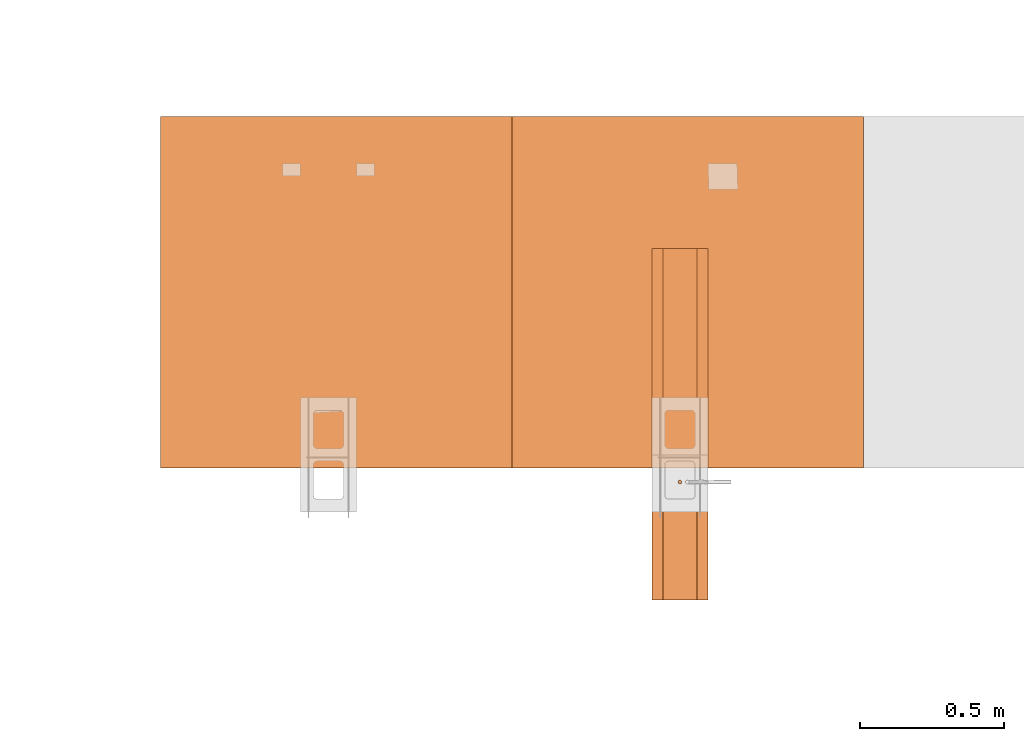
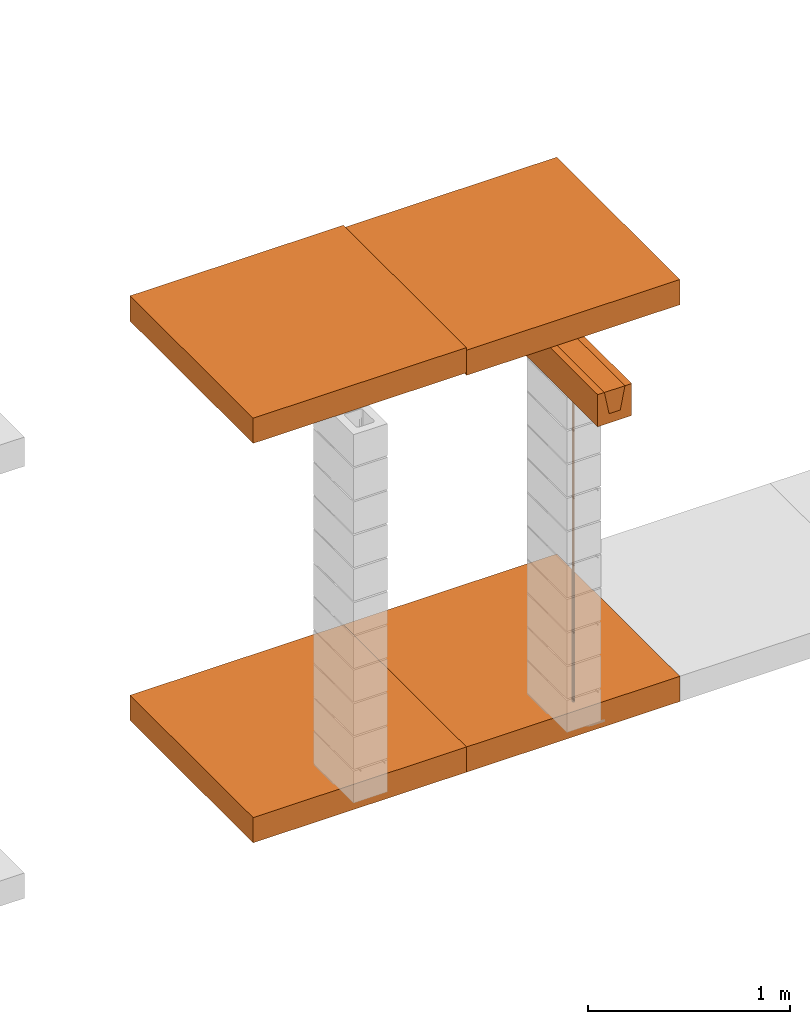
# One storey, part 39 of 64: 7 proxies.
"""IFC4 building model written with IfcOpenShell, lengths in feet."""

from ifc_helpers import new_model, entity, si_unit, converted_unit, frame, origin_with_axes, origin_2d_with_axis, place, context, subcontext, project, spatial, polyline, line, indexed_curve, circle, outline, extrude, material, element, save


model = new_model("IFC4")

# Units and contexts
model_context_1 = context("Model", 3, precision=1e-05, world=origin_with_axes())
plan_context = context("Plan", 2, precision=1e-05, world=origin_2d_with_axis())
model_context_2 = context("Model", 3, precision=1e-05, world=origin_with_axes())
context_of_model_1 = context(None, 3, precision=1e-05, world=origin_with_axes())
context_of_model_2 = context(None, 3, precision=1e-05, world=origin_with_axes())
body_context = subcontext(model_context_2, "Body", "Model", "MODEL_VIEW")
ifc_project = project(units=[converted_unit("PLANEANGLEUNIT", "degree", entity("IfcReal", 0.0174532925199433), si_unit("PLANEANGLEUNIT", "RADIAN"), dimensions=[0, 0, 0, 0, 0, 0, 0]), converted_unit("AREAUNIT", "square foot", entity("IfcReal", 0.09290304), si_unit("AREAUNIT", "SQUARE_METRE"), dimensions=[2, 0, 0, 0, 0, 0, 0]), converted_unit("LENGTHUNIT", "foot", entity("IfcReal", 0.3048), si_unit("LENGTHUNIT", "METRE"), dimensions=[1, 0, 0, 0, 0, 0, 0]), converted_unit("VOLUMEUNIT", "cubic foot", entity("IfcReal", 0.0283168467116885), si_unit("VOLUMEUNIT", "CUBIC_METRE"), dimensions=[3, 0, 0, 0, 0, 0, 0])], contexts=[model_context_1, plan_context, context_of_model_1, context_of_model_2])

# Site, building, storey
site_placement = place(None, origin_with_axes())
site = spatial("IfcSite", under=ifc_project, at=site_placement)
building_placement = place(site_placement, origin_with_axes())
building = spatial("IfcBuilding", under=site, at=building_placement, Name="Building")
storey_placement = place(building_placement, origin_with_axes())
storey = spatial("IfcBuildingStorey", under=building, at=storey_placement, Name="Storey")

# Proxies
proxy_1_placement = place(storey_placement, frame((1419.07288959333, 1.32031249874846, 0.333333329304935), z_axis=(0.0, 0.0, 1.0), x_axis=(-1.62920684942944e-07, 0.999999999999987, 0.0)))
element("IfcBuildingElementProxy", 1, at=proxy_1_placement, inside=storey, Name="Dowel1:Dowel", PredefinedType="COMPLEX", context=body_context, shape_type="SweptSolid", body=[
    extrude(circle(Radius=0.020833332015011, at=origin_2d_with_axis()), frame((0.0208333315537983, -0.0208333361370787, 0.0), z_axis=(0.0, 0.0, -1.0), x_axis=(-0.464723169803619, -0.885456025600433, 0.0)), (0.0, 2.51138637663573e-10, -0.999999940395355), 6.08333335196214),
])
proxy_2_placement = place(storey_placement, frame((1413.1823362015, 5.49999982353271, 7.41666696203036), z_axis=(4.37113882867379e-08, -0.999999999999999, -8.51092183247426e-15), x_axis=(1.94707183709394e-07, 0.0, 0.999999999999981)))
element("IfcBuildingElementProxy", 2, at=proxy_2_placement, inside=storey, Name="Generic Models 513:Generic Models 1", PredefinedType="COMPLEX", context=body_context, shape_type="SweptSolid", body=[
    extrude(outline(polyline([(-0.250000003089742, -2.00000002471794), (0.250000003089742, -2.00000002471794), (0.250000003089742, 2.00000002471794), (-0.250000003089742, 2.00000002471794), (-0.250000003089742, -2.00000002471794)])), frame((0.250000394196335, -2.00000002471794, -6.29525198374314e-07), z_axis=(0.0, 1.19209289550781e-07, -1.0), x_axis=(1.0, 1.94707183709397e-07, 0.0)), (4.23038687413779e-10, -9.26340160134487e-09, -1.0), 4.00000000752362),
])
ifc_material = material(Name="STRUCTURAL FLOOR", Category="concrete")
proxy_3_placement = place(storey_placement, frame((1413.1823362015, 5.49999982353271, -0.500000006179484), z_axis=(4.37113882867379e-08, -0.999999999999999, -8.51092183247426e-15), x_axis=(1.94707183709394e-07, 0.0, 0.999999999999981)))
element("IfcBuildingElementProxy", 3, at=proxy_3_placement, inside=storey, material=ifc_material, Name="Generic Models 514:Generic Models 1", PredefinedType="COMPLEX", context=body_context, shape_type="SweptSolid", body=[
    extrude(outline(polyline([(-0.250000003089742, -2.00000002471794), (0.250000003089742, -2.00000002471794), (0.250000003089742, 2.00000002471794), (-0.250000003089742, 2.00000002471794), (-0.250000003089742, -2.00000002471794)])), frame((0.250000394196335, -2.00000002471794, -6.29525198374314e-07), z_axis=(0.0, 1.19209289550781e-07, -1.0), x_axis=(1.0, 1.94707183709397e-07, 0.0)), (4.23038687413779e-10, -9.26340160134487e-09, -1.0), 4.00000000752362),
])
proxy_4_placement = place(storey_placement, frame((1418.77602404497, 4.00000004943587, 6.6979162962105), z_axis=(4.37113882867379e-08, -0.999999999999999, -8.51092183247426e-15), x_axis=(1.94707183709394e-07, 0.0, 0.999999999999981)))
element("IfcBuildingElementProxy", 4, at=proxy_4_placement, inside=storey, Name="Generic Models 549:Generic Models 1", PredefinedType="COMPLEX", context=body_context, shape_type="SweptSolid", body=[
    extrude(outline(indexed_curve([(-0.303117656136748, 0.137395135021898), (0.155215735823464, 0.137395135021898), (0.19538262736766, -0.0692456545127346), (-0.229576710132476, -0.240940409969157), (-0.20572561232906, -0.363643796933605), (0.418016779923376, -0.2424006553225), (0.296773564979786, 0.381341761374098), (-0.326968802828488, 0.260098546430508)], segments=[line(5, 6), line(6, 7), line(7, 8), line(8, 1), line(1, 2), line(2, 3), line(3, 4), line(4, 5)], self_intersect=False)), frame((0.364084451843122, -0.317708278695742, -3.78737869296346e-08), z_axis=(-3.54481560478712e-14, 1.19209289550781e-07, -1.0), x_axis=(-0.981627225875854, -0.190809190273285, -2.2746196037815e-08)), (1.70205058380724e-10, -5.2017301577223e-09, -1.0), 4.0),
])
proxy_5_placement = place(storey_placement, frame((1417.18226154958, 5.49999982353271, -0.500000006179484), z_axis=(4.37113882867379e-08, -0.999999999999999, -8.51092183247426e-15), x_axis=(1.94707183709394e-07, 0.0, 0.999999999999981)))
element("IfcBuildingElementProxy", 5, at=proxy_5_placement, inside=storey, material=ifc_material, Name="Generic Models 349:Generic Models 1", PredefinedType="COMPLEX", context=body_context, shape_type="SweptSolid", body=[
    extrude(outline(polyline([(-0.250000003089742, -2.00000002471794), (0.250000003089742, -2.00000002471794), (0.250000003089742, 2.00000002471794), (-0.250000003089742, 2.00000002471794), (-0.250000003089742, -2.00000002471794)])), frame((0.250000394196335, -2.00000002471794, -2.3841858204817e-07), z_axis=(0.0, 1.19209289550781e-07, -1.0), x_axis=(1.0, 1.94707183709397e-07, -8.51092267950722e-15)), (4.23030166452065e-10, -9.26341314766432e-09, -1.0), 4.00000000752362),
])
proxy_6_placement = place(storey_placement, frame((1419.28645256623, -9.77766482535935e-08, 6.88342128212996), z_axis=(-1.19248806385031e-08, 1.0, 2.32186003347565e-15), x_axis=(1.94707183709394e-07, 0.0, 0.999999999999981)))
element("IfcBuildingElementProxy", 6, at=proxy_6_placement, inside=storey, Name="Generic Models 369:Generic Models 1", PredefinedType="COMPLEX", context=body_context, shape_type="SweptSolid", body=[
    extrude(outline(indexed_curve([(-0.105254239649597, 0.224956225730929), (0.105254202983354, 0.224956225730929), (0.192708338261276, -0.224956225730929), (-0.192708338261276, -0.224956225730929)], segments=[line(4, 1), line(1, 2), line(2, 3), line(3, 4)], self_intersect=False)), frame((0.224956274619253, -0.192708778256194, 4.00000004943587), z_axis=(0.0, 0.0, -1.0), x_axis=(2.53690757290315e-07, -1.0, 0.0)), (-1.20175570827996e-07, -2.18547841160529e-15, 1.0), 4.0),
])
proxy_7_placement = place(storey_placement, frame((1417.18226154958, 5.49999982353271, 7.36458329703864), z_axis=(4.37113882867379e-08, -0.999999999999999, -8.51092183247426e-15), x_axis=(1.94707183709394e-07, 0.0, 0.999999999999981)))
element("IfcBuildingElementProxy", 7, at=proxy_7_placement, inside=storey, Name="Generic Models 384:Generic Models 1", PredefinedType="COMPLEX", context=body_context, shape_type="SweptSolid", body=[
    extrude(outline(polyline([(-0.250000003089742, -2.00000002471794), (0.250000003089742, -2.00000002471794), (0.250000003089742, 2.00000002471794), (-0.250000003089742, 2.00000002471794), (-0.250000003089742, -2.00000002471794)])), frame((0.250000394196335, -2.00000002471794, -2.3841858204817e-07), z_axis=(0.0, 1.19209289550781e-07, -1.0), x_axis=(1.0, 1.94707183709397e-07, -8.51092267950722e-15)), (4.23030166452065e-10, -9.26341314766432e-09, -1.0), 4.00000000752362),
])

save(model, "model.ifc")
